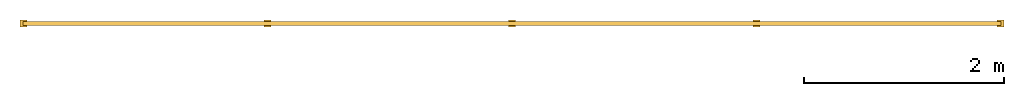
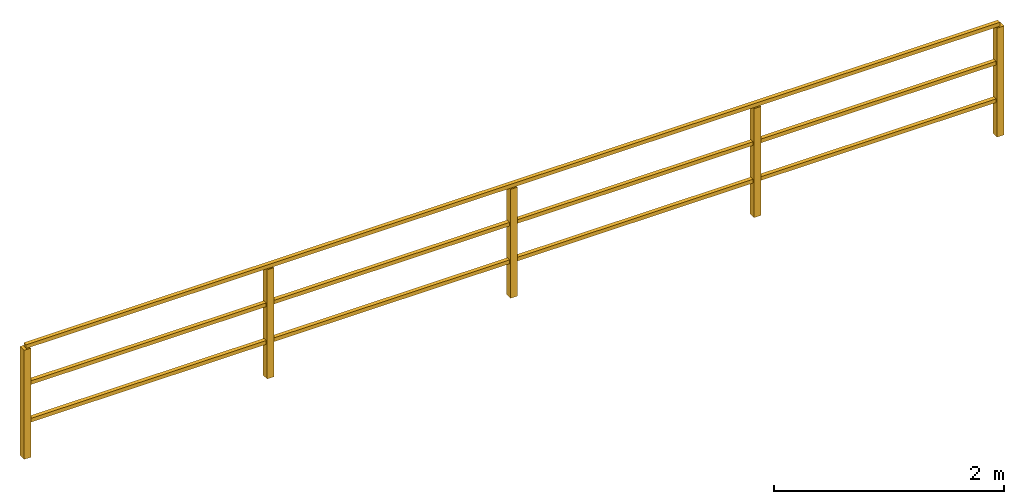
# Not in any storey: 1 railing.
"""IFC4 model written with IfcOpenShell, lengths in metres."""

from ifc_helpers import new_model, entity, si_unit, converted_unit, derived_unit, direction, frame, frame_2d, origin, place, context, subcontext, project, spatial, rectangle, extrude, material, element, save


model = new_model("IFC4")

# Units and contexts
model_context = context("Model", 3, precision=1e-05, world=origin(), true_north=direction((6.12303176911189e-17, 1.0)))
body_context = subcontext(model_context, "Body", "Model", "MODEL_VIEW")
ifc_project = project(units=[si_unit("LENGTHUNIT", "METRE"), si_unit("AREAUNIT", "SQUARE_METRE"), si_unit("VOLUMEUNIT", "CUBIC_METRE"), converted_unit("PLANEANGLEUNIT", "DEGREE", entity("IfcRatioMeasure", 0.0174532925199433), si_unit("PLANEANGLEUNIT", "RADIAN"), dimensions=[0, 0, 0, 0, 0, 0, 0]), si_unit("MASSUNIT", "GRAM", prefix="KILO"), derived_unit("MASSDENSITYUNIT", [(si_unit("MASSUNIT", "GRAM", prefix="KILO"), 1), (si_unit("LENGTHUNIT", "METRE"), -3)]), derived_unit("MOMENTOFINERTIAUNIT", [(si_unit("LENGTHUNIT", "METRE"), 4)]), si_unit("TIMEUNIT", "SECOND"), si_unit("FREQUENCYUNIT", "HERTZ"), si_unit("THERMODYNAMICTEMPERATUREUNIT", "DEGREE_CELSIUS"), derived_unit("THERMALTRANSMITTANCEUNIT", [(si_unit("MASSUNIT", "GRAM", prefix="KILO"), 1), (si_unit("THERMODYNAMICTEMPERATUREUNIT", "KELVIN"), -1), (si_unit("TIMEUNIT", "SECOND"), -3)]), derived_unit("VOLUMETRICFLOWRATEUNIT", [(si_unit("LENGTHUNIT", "METRE"), 3), (si_unit("TIMEUNIT", "SECOND"), -1)]), si_unit("ELECTRICCURRENTUNIT", "AMPERE"), si_unit("ELECTRICVOLTAGEUNIT", "VOLT"), si_unit("POWERUNIT", "WATT"), si_unit("FORCEUNIT", "NEWTON", prefix="KILO"), si_unit("ILLUMINANCEUNIT", "LUX"), si_unit("LUMINOUSFLUXUNIT", "LUMEN"), si_unit("LUMINOUSINTENSITYUNIT", "CANDELA"), derived_unit("USERDEFINED", [(si_unit("MASSUNIT", "GRAM", prefix="KILO"), -1), (si_unit("LENGTHUNIT", "METRE"), -2), (si_unit("TIMEUNIT", "SECOND"), 3), (si_unit("LUMINOUSFLUXUNIT", "LUMEN"), 1)]), derived_unit("LINEARVELOCITYUNIT", [(si_unit("LENGTHUNIT", "METRE"), 1), (si_unit("TIMEUNIT", "SECOND"), -1)]), si_unit("PRESSUREUNIT", "PASCAL"), derived_unit("USERDEFINED", [(si_unit("LENGTHUNIT", "METRE"), -2), (si_unit("MASSUNIT", "GRAM", prefix="KILO"), 1), (si_unit("TIMEUNIT", "SECOND"), -2)]), derived_unit("LINEARFORCEUNIT", [(si_unit("MASSUNIT", "GRAM", prefix="KILO"), 1), (si_unit("LENGTHUNIT", "METRE"), 1), (si_unit("TIMEUNIT", "SECOND"), -2), (si_unit("LENGTHUNIT", "METRE"), -1)]), derived_unit("PLANARFORCEUNIT", [(si_unit("MASSUNIT", "GRAM", prefix="KILO"), 1), (si_unit("LENGTHUNIT", "METRE"), 1), (si_unit("TIMEUNIT", "SECOND"), -2), (si_unit("LENGTHUNIT", "METRE"), -2)])], contexts=[model_context])

# Site
site_placement = place(None, origin())
site = spatial("IfcSite", under=ifc_project, at=site_placement, CompositionType="ELEMENT")

# Railing
ifc_material = material(Name="Kunststoff - grau 70-70-70", Category="Kunststoff")
railing_placement = place(site_placement, frame((-2.35917445388067, -3.01742114403174, 0.0)))
element("IfcRailing", 1, at=railing_placement, inside=site, material=ifc_material, PredefinedType="NOTDEFINED", context=body_context, shape_type="SweptSolid", body=[
    extrude(rectangle(XDim=0.0699999999999992, YDim=0.0699999999999998, at=frame_2d((0.0, -2.70616862252382e-16), x_axis=(1.0, 0.0))), frame((7.38, 0.035000000000011, 0.0)), (0.0, 0.0, 1.0), 1.16),
    extrude(rectangle(XDim=0.0700000000000009, YDim=0.0699999999999998, at=frame_2d((-2.70616862252382e-16, 2.70616862252382e-16), x_axis=(1.0, 0.0))), frame((4.93, 0.0350000000000207, 0.0)), (0.0, 0.0, 1.0), 1.16),
    extrude(rectangle(XDim=0.07, YDim=0.0699999999999998, at=frame_2d((-1.04083408558608e-17, 2.70616862252382e-16), x_axis=(1.0, 0.0))), frame((2.48, 0.035000000000031, 0.0)), (0.0, 0.0, 1.0), 1.16),
    extrude(rectangle(XDim=0.0699999999999992, YDim=0.0699999999999998, at=frame_2d((0.0, 2.70616862252382e-16), x_axis=(1.0, 0.0))), frame((9.82500000000001, 0.0350000000000007, 0.0)), (0.0, 0.0, 1.0), 1.16),
    extrude(rectangle(XDim=0.0699999999999995, YDim=0.0699999999999998, at=frame_2d((1.35308431126191e-16, 2.70616862252382e-16), x_axis=(1.0, 0.0))), frame((0.0350000000000002, 0.0350000000000413, 0.0)), (0.0, 0.0, 1.0), 1.16),
    extrude(rectangle(XDim=9.8, YDim=0.0400000000000001, at=frame_2d((0.0, -2.70616862252382e-16), x_axis=(1.0, 0.0))), frame((4.93, 0.0350000000000213, 1.16)), (0.0, 0.0, 1.0), 0.04),
    extrude(rectangle(XDim=9.8, YDim=0.0400000000000001, at=frame_2d((0.0, -2.70616862252382e-16), x_axis=(1.0, 0.0))), frame((4.93, 0.0350000000000213, 0.76)), (0.0, 0.0, 1.0), 0.04),
    extrude(rectangle(XDim=9.8, YDim=0.0400000000000001, at=frame_2d((0.0, -2.70616862252382e-16), x_axis=(1.0, 0.0))), frame((4.93, 0.0350000000000213, 0.36)), (0.0, 0.0, 1.0), 0.04),
])

save(model, "model.ifc")
